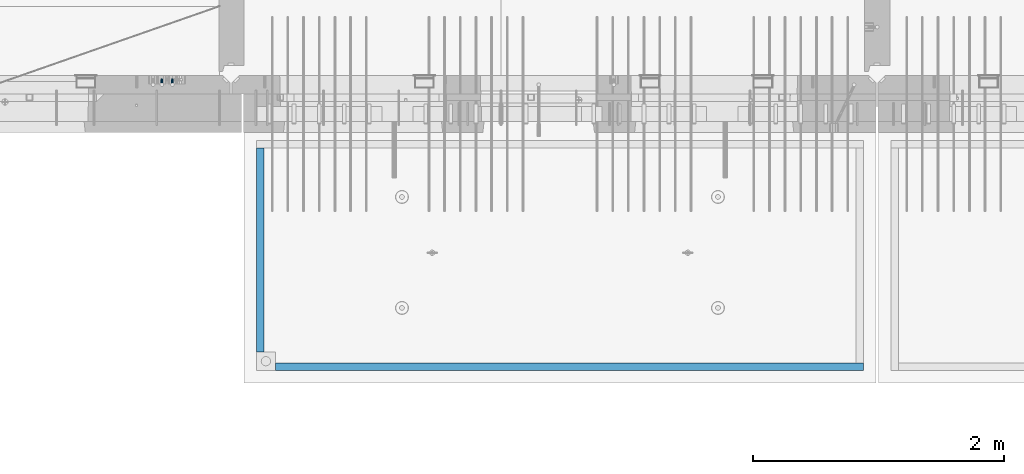
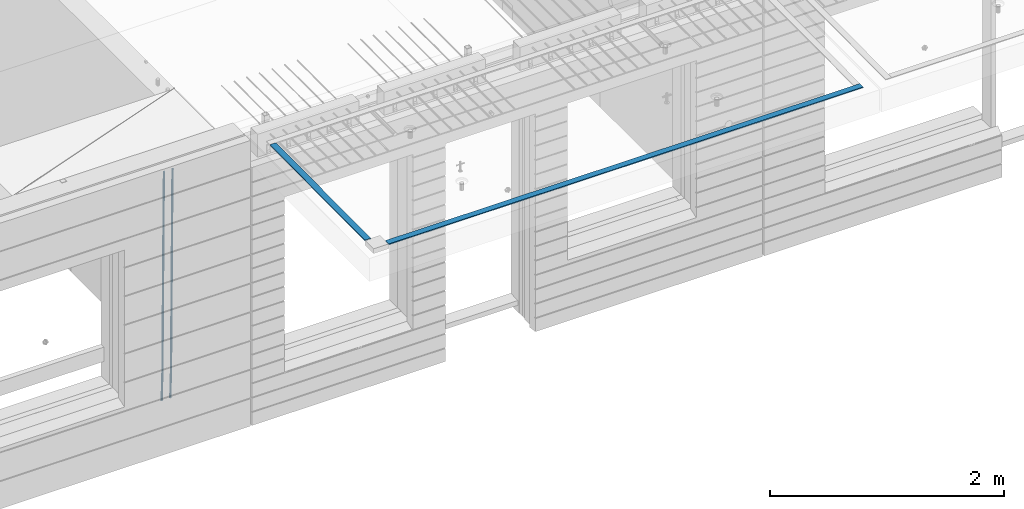
# One storey, part 94 of 352: 4 beams, 2 elements without a shape of their own.
"""IFC2X3 building model written with IfcOpenShell, lengths in millimetres."""

from ifc_helpers import new_model, si_unit, frame, origin_with_axes, place, context, subcontext, project, spatial, faceted_brep, material, type_object, element, aggregate, save


model = new_model("IFC2X3")

# Units and contexts
model_context = context("Model", 3, precision=1e-05, world=origin_with_axes())
body_context = subcontext(model_context, "Body", "Model", "MODEL_VIEW")
ifc_project = project(units=[si_unit("LENGTHUNIT", "METRE", prefix="MILLI"), si_unit("AREAUNIT", "SQUARE_METRE"), si_unit("VOLUMEUNIT", "CUBIC_METRE"), si_unit("MASSUNIT", "GRAM", prefix="KILO"), si_unit("TIMEUNIT", "SECOND"), si_unit("PLANEANGLEUNIT", "RADIAN"), si_unit("SOLIDANGLEUNIT", "STERADIAN"), si_unit("THERMODYNAMICTEMPERATUREUNIT", "DEGREE_CELSIUS"), si_unit("LUMINOUSINTENSITYUNIT", "LUMEN")], contexts=[model_context])

# Site, building, storey
site_placement = place(None, origin_with_axes())
site = spatial("IfcSite", under=ifc_project, at=site_placement, CompositionType="ELEMENT")
building_placement = place(site_placement, origin_with_axes())
building = spatial("IfcBuilding", under=site, at=building_placement, CompositionType="ELEMENT")
storey_placement = place(building_placement, origin_with_axes())
storey = spatial("IfcBuildingStorey", under=building, at=storey_placement, Name="6", CompositionType="ELEMENT", Elevation=0.0)

# Assembly, beams
assembly_1_placement = place(storey_placement, origin_with_axes())
assembly_1 = element("IfcElementAssembly", 1, at=assembly_1_placement, inside=storey, AssemblyPlace="NOTDEFINED", PredefinedType="REINFORCEMENT_UNIT")
ifc_material_1 = material()
beam_type_1 = type_object("IfcBeamType", Name="D20", PredefinedType="NOTDEFINED")
beam_1_placement = place(assembly_1_placement, frame((16189.9999999961, 7965.00000227913, 96990.0), z_axis=(0.00020576299992186, -0.999642804629538, -0.0267249099901004), x_axis=(-4.30000201928125e-08, -0.0267249099948059, 0.999642825806181)))
beam_1 = element("IfcBeam", 2, at=beam_1_placement, type_object=beam_type_1, material=ifc_material_1, Name="JM20", ObjectType="D20", context=body_context, shape_type="Brep", body=[
    faceted_brep([(0.0, -10.0, 0.0), (-4.19531716033816e-08, -7.07106781186667, -7.07106781187031), (60.4266690400545, -7.0710677960451, -7.07106780570757), (60.4266690441291, -9.99999998418934, 6.15546014159918e-09), (0.0, 0.0, -10.0), (60.426669036824, 1.58106558956206e-08, -9.99999999384454), (4.196772351861e-08, 7.07106781186303, -7.07106781186667), (60.4266690363438, 7.07106782768096, -7.07106780570757), (0.0, 10.0, 0.0), (60.4266690388904, 10.0000000158179, 6.15182216279209e-09), (4.196772351861e-08, 7.07106781185939, 7.07106781185939), (60.4266690429649, 7.07106782768096, 7.07106781802577), (0.0, 0.0, 10.0), (60.4266690461809, 1.58179318532348e-08, 10.0000000061555), (-4.19531716033816e-08, -7.07106781187031, 7.07106781185939), (60.4266690466611, -7.07106779605238, 7.07106781802213), (61.0378400410118, -7.07106779588503, -7.07106780564936), (60.991799419251, -9.99999998403655, 6.21366780251265e-09), (61.0569027789461, 1.5985278878361e-08, -9.99999999378269), (61.0378209396877, 7.07106782784831, -7.07106780564936), (60.9917724058905, 10.0000000159635, 6.21366780251265e-09), (60.9457317841297, 7.07106782781193, 7.0710678180767), (60.9266690461809, 1.59488990902901e-08, 10.0000000062028), (60.9457508854539, -7.07106779591413, 7.0710678180767), (61.6489592143771, -7.07106614513759, -7.06310863441468), (61.5568818710308, -9.9999984576425, 0.00735959856683621), (61.6870830769039, 1.71821739058942e-06, -9.99179257185824), (61.6489210170112, 7.07106947854481, -7.06310888312146), (61.556827851804, 10.0000015422847, 0.00735924683976918), (61.4647505084577, 7.07106922979438, 7.07782747982128), (61.4266266459163, 1.36643211590126e-06, 10.0065114172685), (61.464788705809, -7.07106639389531, 7.07782772852806), (176.543135720174, -7.07075579406956, -5.56673531796696), (176.451058376813, -9.99968810657447, 1.50373291501455), (176.581259582701, 0.000312069292704109, -8.49541925541052), (176.543097522794, 7.07137982961285, -5.56673556667374), (176.451004357587, 10.00031189336, 1.50373256329476), (176.35892701424, 7.07137958085514, 8.57420079627263), (176.320803151699, 0.000311717507429421, 11.5028847337162), (176.358965211621, -7.07075604281999, 8.57420104497578), (177.098753836006, -7.07075429323595, -5.55949898843028), (176.98362511232, -9.99968666800123, 1.510669025065), (177.146421932586, 0.000313595905026887, -8.48805862247536), (177.098706077581, 7.07138133041735, -5.55949936166144), (176.983557571715, 10.0003133318824, 1.51066849724157), (176.868428848029, 7.07138095712435, 8.58083651073321), (176.820760751449, 0.000313067976094317, 11.5093961447819), (176.868476606425, -7.07075466652896, 8.58083688396073), (177.654312950661, -7.07075204110879, -5.54863964998367), (177.516135294456, -9.99968450931192, 1.52107783331303), (177.711524267797, 0.000315886711177882, -8.47701274570863), (177.654255632195, 7.07138358250813, -5.54864021007961), (177.516054233929, 10.0003154905207, 1.5210770412159), (177.377876577739, 7.0713830223176, 8.59079452451624), (177.320665260588, 0.000315094497636892, 11.5191676202448), (177.377933896176, -7.07075260129932, 8.59079508461218), (299.436796249574, -7.07025836271714, -3.1681962331204), (299.298618593355, -9.99919083092027, 3.90152125031091), (299.494007566798, 0.000809565110102994, -6.09656932889993), (299.436738931283, 7.07187726089978, -3.16819679320906), (299.298537533061, 10.0008091689197, 3.90152045822106), (299.160359876842, 7.07187670072017, 10.9712379416487), (299.103148559603, 0.000808772889286047, 13.8996110374392), (299.160417195119, -7.07025892290039, 10.9712385017483), (299.98743051647, -7.07025613056248, -3.15743315966392), (299.971788958996, -9.99918809853989, 3.91467979818117), (299.993912075952, 0.000811591617093654, -6.08679785393178), (299.987423933868, 7.07187949325817, -3.1574327280432), (299.971753863239, 10.0008119014747, 3.91467990454839), (299.95611230444, 7.07187992653053, 10.9867922621015), (299.949630744944, 0.000812204350950196, 13.9161569563694), (299.956118887014, -7.07025569729012, 10.9867918304735), (300.538107039494, -7.07025785017686, -3.16575821840888), (300.644985195438, -9.99919020432935, 3.90450175465594), (300.493854948218, 0.000810030429420294, -6.09435592770024), (300.538151196495, 7.071877773491, -3.16575855385963), (300.645047642858, 10.0008097955724, 3.90450128024895), (300.751925798773, 7.07187744142357, 10.9747612533101), (300.796177890064, 0.000809560813650023, 13.9033589625978), (300.751881641787, -7.07025818224065, 10.9747615887682), (2293.36490490142, -7.07648090940347, -33.2930642912361), (2293.47178305736, -10.0054132635523, -26.2228043181785), (2293.32065281013, -0.00541302880083094, -36.2216620005347), (2293.36494905842, 7.06565471425711, -33.2930646266868), (2293.47184550477, 9.99458673634581, -26.2228047925819), (2293.57872366071, 7.06565438219332, -19.1525448195243), (2293.62297575199, -0.00541349841296324, -16.2239471102366), (2293.57867950371, -7.0764812414709, -19.1525444840736), (2294.0658245362, -7.07648309818615, -33.3036607065333), (2294.05312277409, -10.0054150789219, -26.2315929392535), (2294.10928714235, -0.00541549149056664, -36.2335844756526), (2294.15805078732, 7.06565223761572, -33.3050546393533), (2294.18355038921, 9.99458451388637, -26.2335642579346), (2294.17084862708, 7.06565253314329, -19.1614964906439), (2294.12738602093, -0.00541507354500936, -16.2315727215355), (2294.07862237596, -7.07648280265857, -19.1601025578348), (2294.76670261032, -7.08562269121467, -33.294332712383), (2294.63442802057, -10.0129954178956, -26.2238563411993), (2294.89787471293, -0.0156988342423574, -36.2230891548279), (2294.95110548967, 7.05531064255774, -33.2944998654275), (2294.89521307347, 9.98530428734011, -26.2240927312887), (2294.76293848372, 7.0579315606592, -19.1536163601049), (2294.63176638114, -0.0119922963167483, -16.2248599176673), (2294.57853560438, -7.08300177311321, -19.1534492070678), (2316.52657204497, -7.36937582653991, -33.0047303660212), (2316.39429745522, -10.2967485532172, -25.9342539948302), (2316.65774414754, -0.299451969567599, -35.9334868084661), (2316.7109749243, 6.7715575072325, -33.0048975190657), (2316.65508250811, 9.70155115201487, -25.9344903849269), (2316.52280791836, 6.7741784253376, -18.8640140137468), (2316.39163581574, -0.295745431634714, -15.9352575713092), (2316.33840503903, -7.36675490843481, -18.863846860706), (2317.16202064224, -7.37766220584308, -32.9962731735213), (2317.05438744847, -10.3053562613532, -25.9254688497131), (2317.23607125619, -0.306993473008333, -35.925789846493), (2317.23316144495, 6.76474808850253, -32.9979477328052), (2317.15499573652, 9.6950321815566, -25.9278370341635), (2317.04736254275, 6.7673381260538, -18.8570327103698), (2316.97331192881, -0.303330606784584, -15.9275160373909), (2316.97622174003, -7.37507216829545, -18.8553581510787), (2317.79752306276, -7.37578610372293, -32.9880110666527), (2317.71453320107, -10.3033876998124, -25.9168792378296), (2317.81444760226, -0.305295583297266, -35.918287695793), (2317.75539265381, 6.76628640723357, -32.9911928173897), (2317.65495180529, 9.69652304524061, -25.9213789128698), (2317.5719619436, 6.76892144914746, -18.8502470840467), (2317.55503740412, -0.301569071270933, -15.9199704549137), (2317.61409235255, -7.3731510618054, -18.847065333317), (2417.8183084176, -7.07752398473531, -31.6906369377139), (2417.73531855589, -10.0051255808248, -24.6195051088798), (2417.83523295709, -0.007033464313281, -34.6209135668432), (2417.77617800863, 7.06454852621755, -31.6938186884508), (2417.67573716014, 9.99478516423187, -24.6240047839383), (2417.59274729842, 7.06718356813872, -17.5528729551006), (2417.57582275895, -0.00330695228694822, -14.6225963259749), (2417.6348777074, -7.07488894281778, -17.5496912043673)], [[[0, 1, 2, 3]], [[1, 4, 5, 2]], [[4, 6, 7, 5]], [[6, 8, 9, 7]], [[8, 10, 11, 9]], [[10, 12, 13, 11]], [[12, 14, 15, 13]], [[14, 0, 3, 15]], [[14, 12, 10, 8, 6, 4, 1, 0]], [[3, 2, 16, 17]], [[2, 5, 18, 16]], [[5, 7, 19, 18]], [[7, 9, 20, 19]], [[9, 11, 21, 20]], [[11, 13, 22, 21]], [[13, 15, 23, 22]], [[15, 3, 17, 23]], [[17, 16, 24, 25]], [[16, 18, 26, 24]], [[18, 19, 27, 26]], [[19, 20, 28, 27]], [[20, 21, 29, 28]], [[21, 22, 30, 29]], [[22, 23, 31, 30]], [[23, 17, 25, 31]], [[25, 24, 32, 33]], [[24, 26, 34, 32]], [[26, 27, 35, 34]], [[27, 28, 36, 35]], [[28, 29, 37, 36]], [[29, 30, 38, 37]], [[30, 31, 39, 38]], [[31, 25, 33, 39]], [[33, 32, 40, 41]], [[32, 34, 42, 40]], [[34, 35, 43, 42]], [[35, 36, 44, 43]], [[36, 37, 45, 44]], [[37, 38, 46, 45]], [[38, 39, 47, 46]], [[39, 33, 41, 47]], [[41, 40, 48, 49]], [[40, 42, 50, 48]], [[42, 43, 51, 50]], [[43, 44, 52, 51]], [[44, 45, 53, 52]], [[45, 46, 54, 53]], [[46, 47, 55, 54]], [[47, 41, 49, 55]], [[49, 48, 56, 57]], [[48, 50, 58, 56]], [[50, 51, 59, 58]], [[51, 52, 60, 59]], [[52, 53, 61, 60]], [[53, 54, 62, 61]], [[54, 55, 63, 62]], [[55, 49, 57, 63]], [[57, 56, 64, 65]], [[56, 58, 66, 64]], [[58, 59, 67, 66]], [[59, 60, 68, 67]], [[60, 61, 69, 68]], [[61, 62, 70, 69]], [[62, 63, 71, 70]], [[63, 57, 65, 71]], [[65, 64, 72, 73]], [[64, 66, 74, 72]], [[66, 67, 75, 74]], [[67, 68, 76, 75]], [[68, 69, 77, 76]], [[69, 70, 78, 77]], [[70, 71, 79, 78]], [[71, 65, 73, 79]], [[73, 72, 80, 81]], [[72, 74, 82, 80]], [[74, 75, 83, 82]], [[75, 76, 84, 83]], [[76, 77, 85, 84]], [[77, 78, 86, 85]], [[78, 79, 87, 86]], [[79, 73, 81, 87]], [[81, 80, 88, 89]], [[80, 82, 90, 88]], [[82, 83, 91, 90]], [[83, 84, 92, 91]], [[84, 85, 93, 92]], [[85, 86, 94, 93]], [[86, 87, 95, 94]], [[87, 81, 89, 95]], [[89, 88, 96, 97]], [[88, 90, 98, 96]], [[90, 91, 99, 98]], [[91, 92, 100, 99]], [[92, 93, 101, 100]], [[93, 94, 102, 101]], [[94, 95, 103, 102]], [[95, 89, 97, 103]], [[97, 96, 104, 105]], [[96, 98, 106, 104]], [[98, 99, 107, 106]], [[99, 100, 108, 107]], [[100, 101, 109, 108]], [[101, 102, 110, 109]], [[102, 103, 111, 110]], [[103, 97, 105, 111]], [[105, 104, 112, 113]], [[104, 106, 114, 112]], [[106, 107, 115, 114]], [[107, 108, 116, 115]], [[108, 109, 117, 116]], [[109, 110, 118, 117]], [[110, 111, 119, 118]], [[111, 105, 113, 119]], [[113, 112, 120, 121]], [[112, 114, 122, 120]], [[114, 115, 123, 122]], [[115, 116, 124, 123]], [[116, 117, 125, 124]], [[117, 118, 126, 125]], [[118, 119, 127, 126]], [[119, 113, 121, 127]], [[121, 120, 128, 129]], [[120, 122, 130, 128]], [[122, 123, 131, 130]], [[123, 124, 132, 131]], [[124, 125, 133, 132]], [[125, 126, 134, 133]], [[126, 127, 135, 134]], [[127, 121, 129, 135]], [[130, 131, 132, 133, 134, 135, 129, 128]]]),
])
beam_2_placement = place(assembly_1_placement, frame((16104.9999999961, 7965.00000227913, 96990.0), z_axis=(0.00020576299992186, -0.999642804629538, -0.0267249099901004), x_axis=(-4.30000201928125e-08, -0.0267249099948059, 0.999642825806181)))
beam_2 = element("IfcBeam", 3, at=beam_2_placement, type_object=beam_type_1, material=ifc_material_1, Name="JM20", ObjectType="D20", context=body_context, shape_type="Brep", body=[
    faceted_brep([(0.0, -10.0, 0.0), (-4.19531716033816e-08, -7.07106781186667, -7.07106781187031), (60.4266690400545, -7.0710677960451, -7.07106780570757), (60.4266690441291, -9.99999998418934, 6.15546014159918e-09), (0.0, 0.0, -10.0), (60.426669036824, 1.58106558956206e-08, -9.99999999384454), (4.196772351861e-08, 7.07106781186303, -7.07106781186667), (60.4266690363438, 7.07106782768096, -7.07106780570757), (0.0, 10.0, 0.0), (60.4266690388904, 10.0000000158179, 6.15182216279209e-09), (4.196772351861e-08, 7.07106781185939, 7.07106781185939), (60.4266690429649, 7.07106782768096, 7.07106781802577), (0.0, 0.0, 10.0), (60.4266690461809, 1.58179318532348e-08, 10.0000000061555), (-4.19531716033816e-08, -7.07106781187031, 7.07106781185939), (60.4266690466611, -7.07106779605238, 7.07106781802213), (61.0378400410118, -7.07106779588503, -7.07106780564936), (60.991799419251, -9.99999998403655, 6.21366780251265e-09), (61.0569027789461, 1.5985278878361e-08, -9.99999999378269), (61.0378209396877, 7.07106782784831, -7.07106780564936), (60.9917724058905, 10.0000000159635, 6.21366780251265e-09), (60.9457317841297, 7.07106782781193, 7.0710678180767), (60.9266690461809, 1.59488990902901e-08, 10.0000000062028), (60.9457508854539, -7.07106779591413, 7.0710678180767), (61.6489592143771, -7.07106614513759, -7.06310863441468), (61.5568818710308, -9.9999984576425, 0.00735959856683621), (61.6870830769039, 1.71821739058942e-06, -9.99179257185824), (61.6489210170112, 7.07106947854481, -7.06310888312146), (61.556827851804, 10.0000015422847, 0.00735924683976918), (61.4647505084577, 7.07106922979438, 7.07782747982128), (61.4266266459163, 1.36643211590126e-06, 10.0065114172685), (61.464788705809, -7.07106639389531, 7.07782772852806), (176.543135720174, -7.07075579406956, -5.56673531796696), (176.451058376813, -9.99968810657447, 1.50373291501455), (176.581259582701, 0.000312069292704109, -8.49541925541052), (176.543097522794, 7.07137982961285, -5.56673556667374), (176.451004357587, 10.00031189336, 1.50373256329476), (176.35892701424, 7.07137958085514, 8.57420079627263), (176.320803151699, 0.000311717507429421, 11.5028847337162), (176.358965211621, -7.07075604281999, 8.57420104497578), (177.098753836006, -7.07075429323595, -5.55949898843028), (176.98362511232, -9.99968666800123, 1.510669025065), (177.146421932586, 0.000313595905026887, -8.48805862247536), (177.098706077581, 7.07138133041735, -5.55949936166144), (176.983557571715, 10.0003133318824, 1.51066849724157), (176.868428848029, 7.07138095712435, 8.58083651073321), (176.820760751449, 0.000313067976094317, 11.5093961447819), (176.868476606425, -7.07075466652896, 8.58083688396073), (177.654312950661, -7.07075204110879, -5.54863964998367), (177.516135294456, -9.99968450931192, 1.52107783331303), (177.711524267797, 0.000315886711177882, -8.47701274570863), (177.654255632195, 7.07138358250813, -5.54864021007961), (177.516054233929, 10.0003154905207, 1.5210770412159), (177.377876577739, 7.0713830223176, 8.59079452451624), (177.320665260588, 0.000315094497636892, 11.5191676202448), (177.377933896176, -7.07075260129932, 8.59079508461218), (299.436796249574, -7.07025836271714, -3.1681962331204), (299.298618593355, -9.99919083092027, 3.90152125031091), (299.494007566798, 0.000809565110102994, -6.09656932889993), (299.436738931283, 7.07187726089978, -3.16819679320906), (299.298537533061, 10.0008091689197, 3.90152045822106), (299.160359876842, 7.07187670072017, 10.9712379416487), (299.103148559603, 0.000808772889286047, 13.8996110374392), (299.160417195119, -7.07025892290039, 10.9712385017483), (299.98743051647, -7.07025613056248, -3.15743315966392), (299.971788958996, -9.99918809853989, 3.91467979818117), (299.993912075952, 0.000811591617093654, -6.08679785393178), (299.987423933868, 7.07187949325817, -3.1574327280432), (299.971753863239, 10.0008119014747, 3.91467990454839), (299.95611230444, 7.07187992653053, 10.9867922621015), (299.949630744944, 0.000812204350950196, 13.9161569563694), (299.956118887014, -7.07025569729012, 10.9867918304735), (300.538107039494, -7.07025785017686, -3.16575821840888), (300.644985195438, -9.99919020432935, 3.90450175465594), (300.493854948218, 0.000810030429420294, -6.09435592770024), (300.538151196495, 7.071877773491, -3.16575855385963), (300.645047642858, 10.0008097955724, 3.90450128024895), (300.751925798773, 7.07187744142357, 10.9747612533101), (300.796177890064, 0.000809560813650023, 13.9033589625978), (300.751881641787, -7.07025818224065, 10.9747615887682), (2293.36490490142, -7.07648090940347, -33.2930642912361), (2293.47178305736, -10.0054132635523, -26.2228043181785), (2293.32065281013, -0.00541302880083094, -36.2216620005347), (2293.36494905842, 7.06565471425711, -33.2930646266868), (2293.47184550477, 9.99458673634581, -26.2228047925819), (2293.57872366071, 7.06565438219332, -19.1525448195243), (2293.62297575199, -0.00541349841296324, -16.2239471102366), (2293.57867950371, -7.0764812414709, -19.1525444840736), (2294.0658245362, -7.07648309818615, -33.3036607065333), (2294.05312277409, -10.0054150789219, -26.2315929392535), (2294.10928714235, -0.00541549149056664, -36.2335844756526), (2294.15805078732, 7.06565223761572, -33.3050546393533), (2294.18355038921, 9.99458451388637, -26.2335642579346), (2294.17084862708, 7.06565253314329, -19.1614964906439), (2294.12738602093, -0.00541507354500936, -16.2315727215355), (2294.07862237596, -7.07648280265857, -19.1601025578348), (2294.76670261032, -7.08562269121467, -33.294332712383), (2294.63442802057, -10.0129954178956, -26.2238563411993), (2294.89787471293, -0.0156988342423574, -36.2230891548279), (2294.95110548967, 7.05531064255774, -33.2944998654275), (2294.89521307347, 9.98530428734011, -26.2240927312887), (2294.76293848372, 7.0579315606592, -19.1536163601049), (2294.63176638114, -0.0119922963167483, -16.2248599176673), (2294.57853560438, -7.08300177311321, -19.1534492070678), (2316.52657204497, -7.36937582653991, -33.0047303660212), (2316.39429745522, -10.2967485532172, -25.9342539948302), (2316.65774414754, -0.299451969567599, -35.9334868084661), (2316.7109749243, 6.7715575072325, -33.0048975190657), (2316.65508250811, 9.70155115201487, -25.9344903849269), (2316.52280791836, 6.7741784253376, -18.8640140137468), (2316.39163581574, -0.295745431634714, -15.9352575713092), (2316.33840503903, -7.36675490843481, -18.863846860706), (2317.16202064224, -7.37766220584308, -32.9962731735213), (2317.05438744847, -10.3053562613532, -25.9254688497131), (2317.23607125619, -0.306993473008333, -35.925789846493), (2317.23316144495, 6.76474808850253, -32.9979477328052), (2317.15499573652, 9.6950321815566, -25.9278370341635), (2317.04736254275, 6.7673381260538, -18.8570327103698), (2316.97331192881, -0.303330606784584, -15.9275160373909), (2316.97622174003, -7.37507216829545, -18.8553581510787), (2317.79752306276, -7.37578610372293, -32.9880110666527), (2317.71453320107, -10.3033876998124, -25.9168792378296), (2317.81444760226, -0.305295583297266, -35.918287695793), (2317.75539265381, 6.76628640723357, -32.9911928173897), (2317.65495180529, 9.69652304524061, -25.9213789128698), (2317.5719619436, 6.76892144914746, -18.8502470840467), (2317.55503740412, -0.301569071270933, -15.9199704549137), (2317.61409235255, -7.3731510618054, -18.847065333317), (2417.8183084176, -7.07752398473531, -31.6906369377139), (2417.73531855589, -10.0051255808248, -24.6195051088798), (2417.83523295709, -0.007033464313281, -34.6209135668432), (2417.77617800863, 7.06454852621755, -31.6938186884508), (2417.67573716014, 9.99478516423187, -24.6240047839383), (2417.59274729842, 7.06718356813872, -17.5528729551006), (2417.57582275895, -0.00330695228694822, -14.6225963259749), (2417.6348777074, -7.07488894281778, -17.5496912043673)], [[[0, 1, 2, 3]], [[1, 4, 5, 2]], [[4, 6, 7, 5]], [[6, 8, 9, 7]], [[8, 10, 11, 9]], [[10, 12, 13, 11]], [[12, 14, 15, 13]], [[14, 0, 3, 15]], [[14, 12, 10, 8, 6, 4, 1, 0]], [[3, 2, 16, 17]], [[2, 5, 18, 16]], [[5, 7, 19, 18]], [[7, 9, 20, 19]], [[9, 11, 21, 20]], [[11, 13, 22, 21]], [[13, 15, 23, 22]], [[15, 3, 17, 23]], [[17, 16, 24, 25]], [[16, 18, 26, 24]], [[18, 19, 27, 26]], [[19, 20, 28, 27]], [[20, 21, 29, 28]], [[21, 22, 30, 29]], [[22, 23, 31, 30]], [[23, 17, 25, 31]], [[25, 24, 32, 33]], [[24, 26, 34, 32]], [[26, 27, 35, 34]], [[27, 28, 36, 35]], [[28, 29, 37, 36]], [[29, 30, 38, 37]], [[30, 31, 39, 38]], [[31, 25, 33, 39]], [[33, 32, 40, 41]], [[32, 34, 42, 40]], [[34, 35, 43, 42]], [[35, 36, 44, 43]], [[36, 37, 45, 44]], [[37, 38, 46, 45]], [[38, 39, 47, 46]], [[39, 33, 41, 47]], [[41, 40, 48, 49]], [[40, 42, 50, 48]], [[42, 43, 51, 50]], [[43, 44, 52, 51]], [[44, 45, 53, 52]], [[45, 46, 54, 53]], [[46, 47, 55, 54]], [[47, 41, 49, 55]], [[49, 48, 56, 57]], [[48, 50, 58, 56]], [[50, 51, 59, 58]], [[51, 52, 60, 59]], [[52, 53, 61, 60]], [[53, 54, 62, 61]], [[54, 55, 63, 62]], [[55, 49, 57, 63]], [[57, 56, 64, 65]], [[56, 58, 66, 64]], [[58, 59, 67, 66]], [[59, 60, 68, 67]], [[60, 61, 69, 68]], [[61, 62, 70, 69]], [[62, 63, 71, 70]], [[63, 57, 65, 71]], [[65, 64, 72, 73]], [[64, 66, 74, 72]], [[66, 67, 75, 74]], [[67, 68, 76, 75]], [[68, 69, 77, 76]], [[69, 70, 78, 77]], [[70, 71, 79, 78]], [[71, 65, 73, 79]], [[73, 72, 80, 81]], [[72, 74, 82, 80]], [[74, 75, 83, 82]], [[75, 76, 84, 83]], [[76, 77, 85, 84]], [[77, 78, 86, 85]], [[78, 79, 87, 86]], [[79, 73, 81, 87]], [[81, 80, 88, 89]], [[80, 82, 90, 88]], [[82, 83, 91, 90]], [[83, 84, 92, 91]], [[84, 85, 93, 92]], [[85, 86, 94, 93]], [[86, 87, 95, 94]], [[87, 81, 89, 95]], [[89, 88, 96, 97]], [[88, 90, 98, 96]], [[90, 91, 99, 98]], [[91, 92, 100, 99]], [[92, 93, 101, 100]], [[93, 94, 102, 101]], [[94, 95, 103, 102]], [[95, 89, 97, 103]], [[97, 96, 104, 105]], [[96, 98, 106, 104]], [[98, 99, 107, 106]], [[99, 100, 108, 107]], [[100, 101, 109, 108]], [[101, 102, 110, 109]], [[102, 103, 111, 110]], [[103, 97, 105, 111]], [[105, 104, 112, 113]], [[104, 106, 114, 112]], [[106, 107, 115, 114]], [[107, 108, 116, 115]], [[108, 109, 117, 116]], [[109, 110, 118, 117]], [[110, 111, 119, 118]], [[111, 105, 113, 119]], [[113, 112, 120, 121]], [[112, 114, 122, 120]], [[114, 115, 123, 122]], [[115, 116, 124, 123]], [[116, 117, 125, 124]], [[117, 118, 126, 125]], [[118, 119, 127, 126]], [[119, 113, 121, 127]], [[121, 120, 128, 129]], [[120, 122, 130, 128]], [[122, 123, 131, 130]], [[123, 124, 132, 131]], [[124, 125, 133, 132]], [[125, 126, 134, 133]], [[126, 127, 135, 134]], [[127, 121, 129, 135]], [[130, 131, 132, 133, 134, 135, 129, 128]]]),
])
aggregate(assembly_1, [beam_1, beam_2])

assembly_2_placement = place(storey_placement, origin_with_axes())
assembly_2 = element("IfcElementAssembly", 4, at=assembly_2_placement, inside=storey, AssemblyPlace="NOTDEFINED", PredefinedType="REINFORCEMENT_UNIT")
ifc_material_2 = material(Name="CONCRETE/Concrete_Undefined")
beam_type_2 = type_object("IfcBeamType", PredefinedType="NOTDEFINED")
beam_3_placement = place(assembly_2_placement, frame((17009.999743725, 5674.95858499901, 99709.8102146119), z_axis=(0.000380798000187366, 3.00000010760189e-09, 0.999999927496439), x_axis=(0.99999992747398, 6.70200000315108e-06, -0.000380798000181631)))
beam_3 = element("IfcBeam", 5, at=beam_3_placement, type_object=beam_type_2, material=ifc_material_2, context=body_context, shape_type="Brep", body=[
    faceted_brep([(2.5465851649642e-11, 29.9999999999982, -4.99999999998545), (-2.91038304567337e-11, 29.9999999999982, 5.0), (4690.00295566467, 30.0, 5.00000000001455), (4690.00295566467, 30.0000000000009, -4.99999999998545), (-2.5465851649642e-11, -30.0000000000018, 5.0), (4690.00295566467, -30.0, 5.00000000001455), (2.72848410531878e-11, -30.0000000000018, -4.99999999998545), (4690.00295566467, -30.0, -5.0)], [[[0, 1, 2, 3]], [[1, 4, 5, 2]], [[4, 6, 7, 5]], [[6, 0, 3, 7]], [[5, 7, 3, 2]], [[6, 4, 1, 0]]]),
])
beam_4_placement = place(assembly_2_placement, frame((16889.9913896902, 7420.06323332097, 99723.6636421195), z_axis=(3.06000001756964e-07, -0.00861454800079991, 0.9999628940929), x_axis=(3.55420000171828e-05, -0.999962893461279, -0.00861454800397781)))
beam_4 = element("IfcBeam", 6, at=beam_4_placement, type_object=beam_type_2, material=ifc_material_2, context=body_context, shape_type="Brep", body=[
    faceted_brep([(2.5465851649642e-11, 29.9999999999982, -4.99999999998545), (-2.91038304567337e-11, 29.9999999999982, 5.0), (1625.15608040099, 30.0000000000073, 5.0), (1625.15608040101, 30.0000000000036, -4.99999999998545), (-2.5465851649642e-11, -30.0000000000018, 5.0), (1625.15608040099, -29.9999999999964, 5.0), (2.72848410531878e-11, -30.0000000000018, -4.99999999998545), (1625.15608040101, -29.9999999999964, -4.99999999998545)], [[[0, 1, 2, 3]], [[1, 4, 5, 2]], [[4, 6, 7, 5]], [[6, 0, 3, 7]], [[5, 7, 3, 2]], [[6, 4, 1, 0]]]),
])
aggregate(assembly_2, [beam_3, beam_4])

save(model, "model.ifc")
